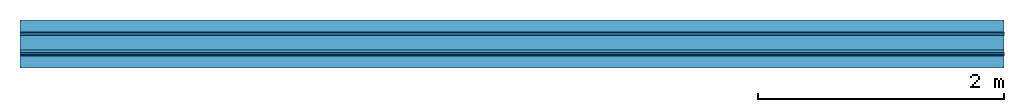
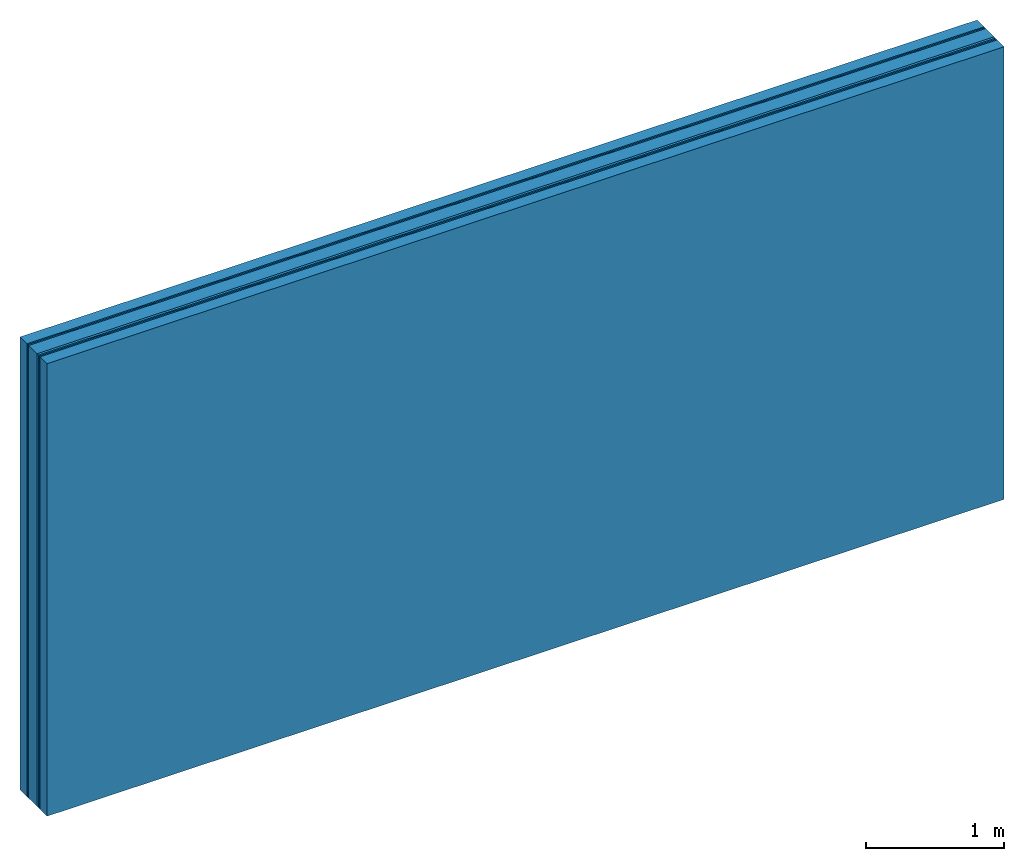
# One storey: 6 plates, 2 members, 1 element without a shape of its own.
"""IFC4 building model written with IfcOpenShell, lengths in metres."""

from ifc_helpers import new_model, si_unit, derived_unit, direction, frame, frame_2d, origin, place, context, project, spatial, rectangle, extrude, material, layer, layer_set, type_object, element, aggregate, save


model = new_model("IFC4")

# Units and contexts
plan_context = context("Plan", 3, precision=1e-05, world=origin(), true_north=direction((0.0, 1.0)))
model_context = context("Model", 3, precision=1e-05, world=origin(), true_north=direction((0.0, 1.0)))
ifc_project = project(units=[si_unit("LENGTHUNIT", "METRE"), derived_unit("SOUNDPRESSUREUNIT", [(si_unit("PRESSUREUNIT", "PASCAL", prefix="MICRO"), 0)]), si_unit("ENERGYUNIT", "JOULE", prefix="MEGA"), si_unit("MASSUNIT", "GRAM", prefix="KILO"), derived_unit("THERMALTRANSMITTANCEUNIT", [(si_unit("POWERUNIT", "WATT"), 1), (si_unit("AREAUNIT", "SQUARE_METRE"), -1), (si_unit("THERMODYNAMICTEMPERATUREUNIT", "KELVIN"), -1)]), derived_unit("AREADENSITYUNIT", [(si_unit("MASSUNIT", "GRAM", prefix="KILO"), 1), (si_unit("AREAUNIT", "SQUARE_METRE"), -1)]), derived_unit("USERDEFINED", [(si_unit("ENERGYUNIT", "JOULE", prefix="MEGA"), 1), (si_unit("AREAUNIT", "SQUARE_METRE"), -1)])], contexts=[plan_context, model_context])

# Site, building, storey
site = spatial("IfcSite", under=ifc_project)
building_placement = place(None, origin())
building = spatial("IfcBuilding", under=site, at=building_placement)
storey_placement = place(building_placement, origin())
storey = spatial("IfcBuildingStorey", under=building, at=storey_placement)

# Wall, members, plates
ifc_layer_1 = layer(None, 0.1, Name="Support")
ifc_material_1 = material(Name="of the art")
ifc_layer_2 = layer(ifc_material_1, 0.0, Name="Bond")
ifc_material_2 = material(Name="Rigidur H", Category="03.007")
ifc_layer_3 = layer(ifc_material_2, 0.0125, Name="outside 1st layer")
ifc_layer_4 = layer(ifc_material_2, 0.0125, Name="outside 2nd layer")
ifc_material_3 = material(Category="10.008")
ifc_layer_5 = layer(ifc_material_3, 0.12, Name="Intermediate insulation")
ifc_material_4 = material(Name="Air")
ifc_layer_6 = layer(ifc_material_4, 0.02, Name="Air gap")
ifc_layer_7 = layer(ifc_material_2, 0.0125, Name="2nd layer")
ifc_layer_8 = layer(ifc_material_2, 0.0125, Name="outside 1st layer")
ifc_layer_9 = layer(ifc_material_1, 0.0, Name="Bond")
ifc_layer_10 = layer(None, 0.1, Name="Support")
ifc_layer_set = layer_set([ifc_layer_1, ifc_layer_2, ifc_layer_3, ifc_layer_4, ifc_layer_5, ifc_layer_6, ifc_layer_7, ifc_layer_8, ifc_layer_9, ifc_layer_10])
wall_type = type_object("IfcWallType", Name="B0323", PredefinedType="NOTDEFINED", material=ifc_layer_set)
wall_placement = place(None, frame((0.0, 0.0, 0.0), z_axis=(0.0, -1.0, 0.0), x_axis=(1.0, 0.0, 0.0)))
wall = element("IfcWall", 1, at=wall_placement, inside=storey, type_object=wall_type, material=ifc_layer_set, Name="Wall #1")
ifc_material_5 = material(Name="OSB")
member_1_placement = place(wall_placement, origin())
member_1 = element("IfcMember", 2, at=member_1_placement, material=ifc_material_5, Name="Support", context=plan_context, shape_type="SweptSolid", body=[
    extrude(rectangle(XDim=1.0, YDim=0.1, at=frame_2d((0.5, 0.05), x_axis=(1.0, 0.0))), frame((0.0, 4.0, 0.0), z_axis=(0.0, -1.0, 0.0), x_axis=(1.0, 0.0, 0.0)), (0.0, 0.0, 1.0), 4.0),
    extrude(rectangle(XDim=1.0, YDim=0.1, at=frame_2d((0.5, 0.05), x_axis=(1.0, 0.0))), frame((1.0, 4.0, 0.0), z_axis=(0.0, -1.0, 0.0), x_axis=(1.0, 0.0, 0.0)), (0.0, 0.0, 1.0), 4.0),
    extrude(rectangle(XDim=1.0, YDim=0.1, at=frame_2d((0.5, 0.05), x_axis=(1.0, 0.0))), frame((2.0, 4.0, 0.0), z_axis=(0.0, -1.0, 0.0), x_axis=(1.0, 0.0, 0.0)), (0.0, 0.0, 1.0), 4.0),
    extrude(rectangle(XDim=1.0, YDim=0.1, at=frame_2d((0.5, 0.05), x_axis=(1.0, 0.0))), frame((3.0, 4.0, 0.0), z_axis=(0.0, -1.0, 0.0), x_axis=(1.0, 0.0, 0.0)), (0.0, 0.0, 1.0), 4.0),
    extrude(rectangle(XDim=1.0, YDim=0.1, at=frame_2d((0.5, 0.05), x_axis=(1.0, 0.0))), frame((4.0, 4.0, 0.0), z_axis=(0.0, -1.0, 0.0), x_axis=(1.0, 0.0, 0.0)), (0.0, 0.0, 1.0), 4.0),
    extrude(rectangle(XDim=1.0, YDim=0.1, at=frame_2d((0.5, 0.05), x_axis=(1.0, 0.0))), frame((5.0, 4.0, 0.0), z_axis=(0.0, -1.0, 0.0), x_axis=(1.0, 0.0, 0.0)), (0.0, 0.0, 1.0), 4.0),
    extrude(rectangle(XDim=1.0, YDim=0.1, at=frame_2d((0.5, 0.05), x_axis=(1.0, 0.0))), frame((6.0, 4.0, 0.0), z_axis=(0.0, -1.0, 0.0), x_axis=(1.0, 0.0, 0.0)), (0.0, 0.0, 1.0), 4.0),
    extrude(rectangle(XDim=1.0, YDim=0.1, at=frame_2d((0.5, 0.05), x_axis=(1.0, 0.0))), frame((7.0, 4.0, 0.0), z_axis=(0.0, -1.0, 0.0), x_axis=(1.0, 0.0, 0.0)), (0.0, 0.0, 1.0), 4.0),
])
member_2_placement = place(wall_placement, origin())
member_2 = element("IfcMember", 3, at=member_2_placement, material=ifc_material_5, Name="Support", context=plan_context, shape_type="SweptSolid", body=[
    extrude(rectangle(XDim=1.0, YDim=0.1, at=frame_2d((0.5, 0.05), x_axis=(1.0, 0.0))), frame((0.0, 4.0, 0.29), z_axis=(0.0, -1.0, 0.0), x_axis=(1.0, 0.0, 0.0)), (0.0, 0.0, 1.0), 4.0),
    extrude(rectangle(XDim=1.0, YDim=0.1, at=frame_2d((0.5, 0.05), x_axis=(1.0, 0.0))), frame((1.0, 4.0, 0.29), z_axis=(0.0, -1.0, 0.0), x_axis=(1.0, 0.0, 0.0)), (0.0, 0.0, 1.0), 4.0),
    extrude(rectangle(XDim=1.0, YDim=0.1, at=frame_2d((0.5, 0.05), x_axis=(1.0, 0.0))), frame((2.0, 4.0, 0.29), z_axis=(0.0, -1.0, 0.0), x_axis=(1.0, 0.0, 0.0)), (0.0, 0.0, 1.0), 4.0),
    extrude(rectangle(XDim=1.0, YDim=0.1, at=frame_2d((0.5, 0.05), x_axis=(1.0, 0.0))), frame((3.0, 4.0, 0.29), z_axis=(0.0, -1.0, 0.0), x_axis=(1.0, 0.0, 0.0)), (0.0, 0.0, 1.0), 4.0),
    extrude(rectangle(XDim=1.0, YDim=0.1, at=frame_2d((0.5, 0.05), x_axis=(1.0, 0.0))), frame((4.0, 4.0, 0.29), z_axis=(0.0, -1.0, 0.0), x_axis=(1.0, 0.0, 0.0)), (0.0, 0.0, 1.0), 4.0),
    extrude(rectangle(XDim=1.0, YDim=0.1, at=frame_2d((0.5, 0.05), x_axis=(1.0, 0.0))), frame((5.0, 4.0, 0.29), z_axis=(0.0, -1.0, 0.0), x_axis=(1.0, 0.0, 0.0)), (0.0, 0.0, 1.0), 4.0),
    extrude(rectangle(XDim=1.0, YDim=0.1, at=frame_2d((0.5, 0.05), x_axis=(1.0, 0.0))), frame((6.0, 4.0, 0.29), z_axis=(0.0, -1.0, 0.0), x_axis=(1.0, 0.0, 0.0)), (0.0, 0.0, 1.0), 4.0),
    extrude(rectangle(XDim=1.0, YDim=0.1, at=frame_2d((0.5, 0.05), x_axis=(1.0, 0.0))), frame((7.0, 4.0, 0.29), z_axis=(0.0, -1.0, 0.0), x_axis=(1.0, 0.0, 0.0)), (0.0, 0.0, 1.0), 4.0),
])
plate_1_placement = place(wall_placement, origin())
plate_1 = element("IfcPlate", 4, at=plate_1_placement, material=ifc_material_2, Name="outside 1st layer", context=plan_context, shape_type="SweptSolid", body=[
    extrude(rectangle(XDim=8.0, YDim=4.0, at=frame_2d((4.0, 2.0), x_axis=(1.0, 0.0))), frame((0.0, 0.0, 0.1), z_axis=(0.0, 0.0, 1.0), x_axis=(1.0, 0.0, 0.0)), (0.0, 0.0, 1.0), 0.0125),
])
plate_2_placement = place(wall_placement, origin())
plate_2 = element("IfcPlate", 5, at=plate_2_placement, material=ifc_material_2, Name="outside 2nd layer", context=plan_context, shape_type="SweptSolid", body=[
    extrude(rectangle(XDim=8.0, YDim=4.0, at=frame_2d((4.0, 2.0), x_axis=(1.0, 0.0))), frame((0.0, 0.0, 0.1125), z_axis=(0.0, 0.0, 1.0), x_axis=(1.0, 0.0, 0.0)), (0.0, 0.0, 1.0), 0.0125),
])
plate_3_placement = place(wall_placement, origin())
plate_3 = element("IfcPlate", 6, at=plate_3_placement, material=ifc_material_3, Name="Intermediate insulation", context=plan_context, shape_type="SweptSolid", body=[
    extrude(rectangle(XDim=8.0, YDim=4.0, at=frame_2d((4.0, 2.0), x_axis=(1.0, 0.0))), frame((0.0, 0.0, 0.125), z_axis=(0.0, 0.0, 1.0), x_axis=(1.0, 0.0, 0.0)), (0.0, 0.0, 1.0), 0.12),
])
plate_4_placement = place(wall_placement, origin())
plate_4 = element("IfcPlate", 7, at=plate_4_placement, material=ifc_material_4, Name="Air gap", context=plan_context, shape_type="SweptSolid", body=[
    extrude(rectangle(XDim=8.0, YDim=4.0, at=frame_2d((4.0, 2.0), x_axis=(1.0, 0.0))), frame((0.0, 0.0, 0.245), z_axis=(0.0, 0.0, 1.0), x_axis=(1.0, 0.0, 0.0)), (0.0, 0.0, 1.0), 0.02),
])
plate_5_placement = place(wall_placement, origin())
plate_5 = element("IfcPlate", 8, at=plate_5_placement, material=ifc_material_2, Name="2nd layer", context=plan_context, shape_type="SweptSolid", body=[
    extrude(rectangle(XDim=8.0, YDim=4.0, at=frame_2d((4.0, 2.0), x_axis=(1.0, 0.0))), frame((0.0, 0.0, 0.265), z_axis=(0.0, 0.0, 1.0), x_axis=(1.0, 0.0, 0.0)), (0.0, 0.0, 1.0), 0.0125),
])
plate_6_placement = place(wall_placement, origin())
plate_6 = element("IfcPlate", 9, at=plate_6_placement, material=ifc_material_2, Name="outside 1st layer", context=plan_context, shape_type="SweptSolid", body=[
    extrude(rectangle(XDim=8.0, YDim=4.0, at=frame_2d((4.0, 2.0), x_axis=(1.0, 0.0))), frame((0.0, 0.0, 0.2775), z_axis=(0.0, 0.0, 1.0), x_axis=(1.0, 0.0, 0.0)), (0.0, 0.0, 1.0), 0.0125),
])
aggregate(wall, [member_1, plate_1, plate_2, plate_3, plate_4, plate_5, plate_6, member_2])

save(model, "model.ifc")
